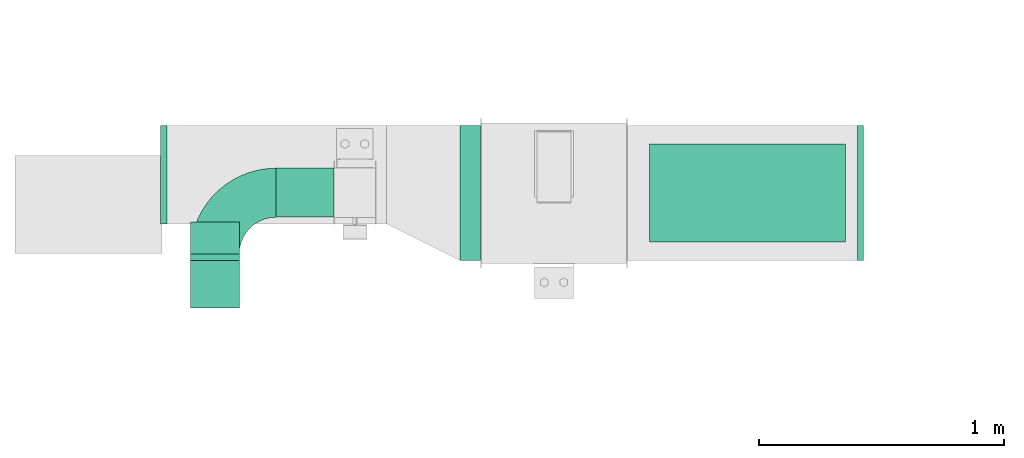
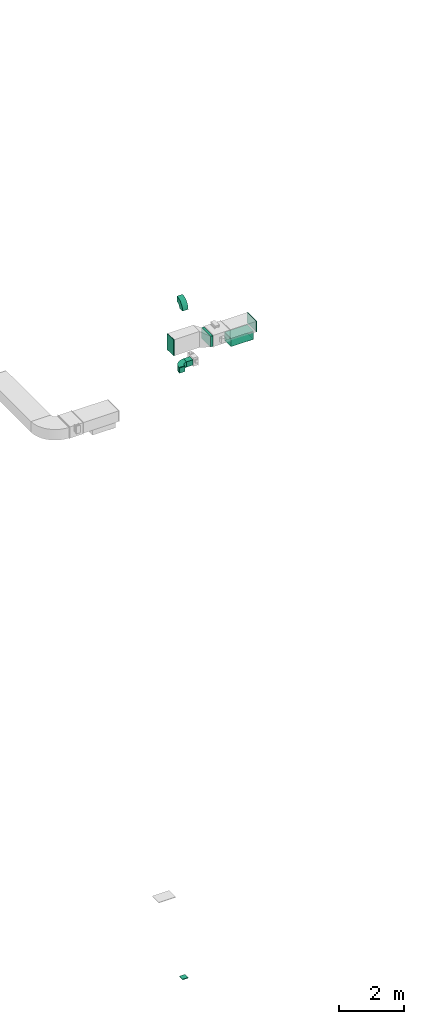
# One storey, part 3 of 9: 7 flow fittings, 3 flow segments, 1 flow terminal.
"""IFC2X3 building model written with IfcOpenShell, lengths in millimetres."""

from ifc_helpers import new_model, entity, si_unit, converted_unit, derived_unit, direction, frame, frame_2d, origin, origin_2d_with_axis, place, context, subcontext, project, spatial, polyline, circle_curve, parameter, trimmed, segment, composite_curve, rectangle, outline, extrude, source, transform, mapped, material, type_object, type_shapes, element, save


model = new_model("IFC2X3")

# Units and contexts
model_context = context("Model", 3, precision=0.01, world=origin(), true_north=direction((6.12303176911189e-17, 1.0)))
body_context = subcontext(model_context, "Body", "Model", "MODEL_VIEW")
ifc_project = project(units=[si_unit("LENGTHUNIT", "METRE", prefix="MILLI"), si_unit("AREAUNIT", "SQUARE_METRE"), si_unit("VOLUMEUNIT", "CUBIC_METRE"), converted_unit("PLANEANGLEUNIT", "DEGREE", entity("IfcRatioMeasure", 0.0174532925199433), si_unit("PLANEANGLEUNIT", "RADIAN"), dimensions=[0, 0, 0, 0, 0, 0, 0]), si_unit("MASSUNIT", "GRAM", prefix="KILO"), derived_unit("MASSDENSITYUNIT", [(si_unit("MASSUNIT", "GRAM", prefix="KILO"), 1), (si_unit("LENGTHUNIT", "METRE"), -3)]), derived_unit("MOMENTOFINERTIAUNIT", [(si_unit("LENGTHUNIT", "METRE"), 4)]), si_unit("TIMEUNIT", "SECOND"), si_unit("FREQUENCYUNIT", "HERTZ"), si_unit("THERMODYNAMICTEMPERATUREUNIT", "DEGREE_CELSIUS"), derived_unit("THERMALTRANSMITTANCEUNIT", [(si_unit("MASSUNIT", "GRAM", prefix="KILO"), 1), (si_unit("THERMODYNAMICTEMPERATUREUNIT", "KELVIN"), -1), (si_unit("TIMEUNIT", "SECOND"), -3)]), derived_unit("VOLUMETRICFLOWRATEUNIT", [(si_unit("LENGTHUNIT", "METRE"), 3), (si_unit("TIMEUNIT", "SECOND"), -1)]), derived_unit("MASSFLOWRATEUNIT", [(si_unit("MASSUNIT", "GRAM", prefix="KILO"), 1), (si_unit("TIMEUNIT", "SECOND"), -1)]), derived_unit("ROTATIONALFREQUENCYUNIT", [(si_unit("TIMEUNIT", "SECOND"), -1)]), si_unit("ELECTRICCURRENTUNIT", "AMPERE"), si_unit("ELECTRICVOLTAGEUNIT", "VOLT"), si_unit("POWERUNIT", "WATT"), si_unit("FORCEUNIT", "NEWTON", prefix="KILO"), si_unit("ILLUMINANCEUNIT", "LUX"), si_unit("LUMINOUSFLUXUNIT", "LUMEN"), si_unit("LUMINOUSINTENSITYUNIT", "CANDELA"), derived_unit("USERDEFINED", [(si_unit("MASSUNIT", "GRAM", prefix="KILO"), -1), (si_unit("LENGTHUNIT", "METRE"), -2), (si_unit("TIMEUNIT", "SECOND"), 3), (si_unit("LUMINOUSFLUXUNIT", "LUMEN"), 1)]), derived_unit("LINEARVELOCITYUNIT", [(si_unit("LENGTHUNIT", "METRE"), 1), (si_unit("TIMEUNIT", "SECOND"), -1)]), si_unit("PRESSUREUNIT", "PASCAL"), derived_unit("USERDEFINED", [(si_unit("LENGTHUNIT", "METRE"), -2), (si_unit("MASSUNIT", "GRAM", prefix="KILO"), 1), (si_unit("TIMEUNIT", "SECOND"), -2)]), derived_unit("LINEARFORCEUNIT", [(si_unit("MASSUNIT", "GRAM", prefix="KILO"), 1), (si_unit("LENGTHUNIT", "METRE"), 1), (si_unit("TIMEUNIT", "SECOND"), -2), (si_unit("LENGTHUNIT", "METRE"), -1)]), derived_unit("PLANARFORCEUNIT", [(si_unit("MASSUNIT", "GRAM", prefix="KILO"), 1), (si_unit("LENGTHUNIT", "METRE"), 1), (si_unit("TIMEUNIT", "SECOND"), -2), (si_unit("LENGTHUNIT", "METRE"), -2)])], contexts=[model_context])

# Site, building, storey
site_placement = place(None, origin())
site = spatial("IfcSite", under=ifc_project, at=site_placement, CompositionType="ELEMENT")
building_placement = place(site_placement, origin())
building = spatial("IfcBuilding", under=site, at=building_placement, CompositionType="ELEMENT")
storey_placement = place(building_placement, frame((0.0, 0.0, 24000.0)))
storey = spatial("IfcBuildingStorey", under=building, at=storey_placement, CompositionType="ELEMENT", Elevation=24000.0)

# Flow segments
duct_segment_type = type_object("IfcDuctSegmentType", PredefinedType="NOTDEFINED")
flow_segment_1_placement = place(storey_placement, frame((11245.77, 14444.08, 3200.0)))
element("IfcFlowSegment", 1, at=flow_segment_1_placement, inside=storey, type_object=duct_segment_type, context=body_context, shape_type="SweptSolid", body=[
    extrude(rectangle(XDim=82.7176589595067, YDim=550.000000000001, at=origin_2d_with_axis()), frame((41.36, 275.0, 0.0)), (0.0, 0.0, 1.0), 399.999999999996),
])
flow_segment_2_placement = place(storey_placement, frame((12017.13, 14519.08, 2900.0)))
element("IfcFlowSegment", 2, at=flow_segment_2_placement, inside=storey, type_object=duct_segment_type, context=body_context, shape_type="SweptSolid", body=[
    extrude(rectangle(XDim=800.0, YDim=400.0, at=origin_2d_with_axis()), frame((400.0, 200.0, 0.0)), (0.0, 0.0, 1.0), 280.000000000006),
])
flow_segment_3_placement = place(storey_placement, frame((10494.72, 14620.84, 2600.0)))
element("IfcFlowSegment", 3, at=flow_segment_3_placement, inside=storey, type_object=duct_segment_type, context=body_context, shape_type="SweptSolid", body=[
    extrude(rectangle(XDim=236.407017077476, YDim=200.0, at=origin_2d_with_axis()), frame((118.2, 100.0, 0.0), z_axis=(0.0, 0.0, 1.0), x_axis=(-1.0, 0.0, 0.0)), (0.0, 0.0, 1.0), 199.999999999998),
])

# Flow fittings
ifc_material_1 = material()
duct_fitting_type_1 = type_object("IfcDuctFittingType", PredefinedType="NOTDEFINED", material=ifc_material_1)
shared_shape_1 = source(origin(), body_context, "Body", "SweptSolid", [
    extrude(rectangle(XDim=800.0, YDim=26.096, at=origin_2d_with_axis()), frame((6.95, 0.0, -200.0), z_axis=(0.0, 0.0, 1.0), x_axis=(0.0, -1.0, 0.0)), (0.0, 0.0, 1.0), 400.0),
])
type_shapes(duct_fitting_type_1, [shared_shape_1])
flow_fitting_1_placement = place(storey_placement, frame((12417.13, 14719.08, 3200.0), z_axis=(0.0, 1.0, 0.0), x_axis=(0.0, 0.0, -1.0)))
element("IfcFlowFitting", 4, at=flow_fitting_1_placement, inside=storey, type_object=duct_fitting_type_1, material=ifc_material_1, context=body_context, shape_type="MappedRepresentation", body=[
    mapped(shared_shape_1, transform((0.0, 0.0, 0.0), scale=1.0)),
])
duct_fitting_type_2 = type_object("IfcDuctFittingType", PredefinedType="NOTDEFINED", material=ifc_material_1)
shared_shape_2 = source(origin(), body_context, "Body", "SweptSolid", [
    extrude(rectangle(XDim=24.9999999999999, YDim=550.0, at=origin_2d_with_axis()), frame((12.5, 0.0, -200.0)), (0.0, 0.0, 1.0), 400.0),
])
type_shapes(duct_fitting_type_2, [shared_shape_2])
flow_fitting_2_placement = place(storey_placement, frame((12865.77, 14719.08, 3400.0)))
element("IfcFlowFitting", 5, at=flow_fitting_2_placement, inside=storey, type_object=duct_fitting_type_2, material=ifc_material_1, context=body_context, shape_type="MappedRepresentation", body=[
    mapped(shared_shape_2, transform((0.0, 0.0, 0.0), scale=1.0)),
])
duct_fitting_type_3 = type_object("IfcDuctFittingType", PredefinedType="NOTDEFINED", material=ifc_material_1)
shared_shape_3 = source(origin(), body_context, "Body", "SweptSolid", [
    extrude(rectangle(XDim=600.0, YDim=26.096, at=origin_2d_with_axis()), frame((6.95, 0.0, -200.0), z_axis=(0.0, 0.0, 1.0), x_axis=(0.0, -1.0, 0.0)), (0.0, 0.0, 1.0), 400.0),
])
type_shapes(duct_fitting_type_3, [shared_shape_3])
flow_fitting_3_placement = place(storey_placement, frame((10029.73, 14794.08, 3500.0), z_axis=(0.0, -1.0, 0.0), x_axis=(1.0, 0.0, 0.0)))
element("IfcFlowFitting", 6, at=flow_fitting_3_placement, inside=storey, type_object=duct_fitting_type_3, material=ifc_material_1, context=body_context, shape_type="MappedRepresentation", body=[
    mapped(shared_shape_3, transform((0.0, 0.0, 0.0), scale=1.0)),
])

# Flow terminal
ifc_material_2 = material()
air_terminal_type = type_object("IfcAirTerminalType", PredefinedType="NOTDEFINED", material=ifc_material_2)
shared_shape_4 = source(origin(), body_context, "Body", "SweptSolid", [
    extrude(rectangle(XDim=4.0, YDim=799.999999999999, at=origin_2d_with_axis()), frame((0.0, -2.0, -200.0), z_axis=(0.0, 0.0, 1.0), x_axis=(0.0, 1.0, 0.0)), (0.0, 0.0, 1.0), 400.000000000005),
])
type_shapes(air_terminal_type, [shared_shape_4])
flow_terminal_placement = place(storey_placement, frame((12417.13, 14719.08, 2900.0), z_axis=(0.0, 1.0, 0.0), x_axis=(-1.0, 0.0, 0.0)))
element("IfcFlowTerminal", 7, at=flow_terminal_placement, inside=storey, type_object=air_terminal_type, material=ifc_material_2, context=body_context, shape_type="MappedRepresentation", body=[
    mapped(shared_shape_4, transform((0.0, 0.0, 0.0), scale=1.0)),
])

# Flow fittings
duct_fitting_type_4 = type_object("IfcDuctFittingType", PredefinedType="NOTDEFINED", material=ifc_material_1)
shared_shape_5 = source(origin(), body_context, "Body", "SweptSolid", [
    extrude(rectangle(XDim=24.9999999999999, YDim=200.0, at=origin_2d_with_axis()), frame((12.5, 0.0, -100.0)), (0.0, 0.0, 1.0), 200.0),
])
type_shapes(duct_fitting_type_4, [shared_shape_5])
flow_fitting_4_placement = place(storey_placement, frame((10244.72, 14350.84, -20000.0), z_axis=(0.0, -1.0, 0.0), x_axis=(0.0, 0.0, -1.0)))
element("IfcFlowFitting", 8, at=flow_fitting_4_placement, inside=storey, type_object=duct_fitting_type_4, material=ifc_material_1, context=body_context, shape_type="MappedRepresentation", body=[
    mapped(shared_shape_5, transform((0.0, 0.0, 0.0), scale=1.0)),
])
duct_fitting_type_5 = type_object("IfcDuctFittingType", PredefinedType="NOTDEFINED", material=ifc_material_1)
shared_shape_6 = source(origin(), body_context, "Body", "SweptSolid", [
    extrude(rectangle(XDim=200.0, YDim=26.096, at=origin_2d_with_axis()), frame((6.95, 0.0, -100.0), z_axis=(0.0, 0.0, 1.0), x_axis=(0.0, -1.0, 0.0)), (0.0, 0.0, 1.0), 200.0),
])
type_shapes(duct_fitting_type_5, [shared_shape_6])
flow_fitting_5_placement = place(storey_placement, frame((10244.72, 14450.84, 2700.0), z_axis=(1.0, 0.0, 0.0), x_axis=(0.0, 1.0, 0.0)))
element("IfcFlowFitting", 9, at=flow_fitting_5_placement, inside=storey, type_object=duct_fitting_type_5, material=ifc_material_1, context=body_context, shape_type="MappedRepresentation", body=[
    mapped(shared_shape_6, transform((0.0, 0.0, 0.0), scale=1.0)),
])
duct_fitting_type_6 = type_object("IfcDuctFittingType", PredefinedType="NOTDEFINED", material=ifc_material_1)
shared_shape_7 = source(origin(), body_context, "Body", "SweptSolid", [
    extrude(outline(composite_curve([segment(polyline([(-225.0, -125.0), (-25.0, -125.0)]), True, "CONTINUOUS"), segment(trimmed(circle_curve(frame_2d((125.0, -125.0), x_axis=(0.0, 1.0)), 150.0), [parameter(0.0)], [parameter(90.0000000000001)], True, "PARAMETER"), False, "CONTINUOUS"), segment(polyline([(125.0, 25.0), (125.0, 225.0)]), True, "CONTINUOUS"), segment(trimmed(circle_curve(frame_2d((125.0, -125.0), x_axis=(0.0, 1.0)), 350.0), [parameter(0.0)], [parameter(90.0000000000001)], True, "PARAMETER"), True, "CONTINUOUS")], self_intersect=False)), frame((-125.0, 125.0, -100.0), z_axis=(0.0, 0.0, 1.0), x_axis=(-1.0, 0.0, 0.0)), (0.0, 0.0, 1.0), 200.0),
])
type_shapes(duct_fitting_type_6, [shared_shape_7])
for number, where, z_axis, x_axis in (
    (10, (10244.72, 14720.84, 2700.0), (0.0, 0.0, 1.0), (-1.0, 0.0, 0.0)),
    (11, (10244.72, 14350.84, 5300.0), (-1.0, 0.0, 0.0), (0.0, 0.0, 1.0)),
):
    element("IfcFlowFitting", number, at=place(storey_placement, frame(where, z_axis=z_axis, x_axis=x_axis)), inside=storey, type_object=duct_fitting_type_6, material=ifc_material_1, context=body_context, shape_type="MappedRepresentation", body=[
        mapped(shared_shape_7, transform((0.0, 0.0, 0.0), scale=1.0)),
    ])

save(model, "model.ifc")
